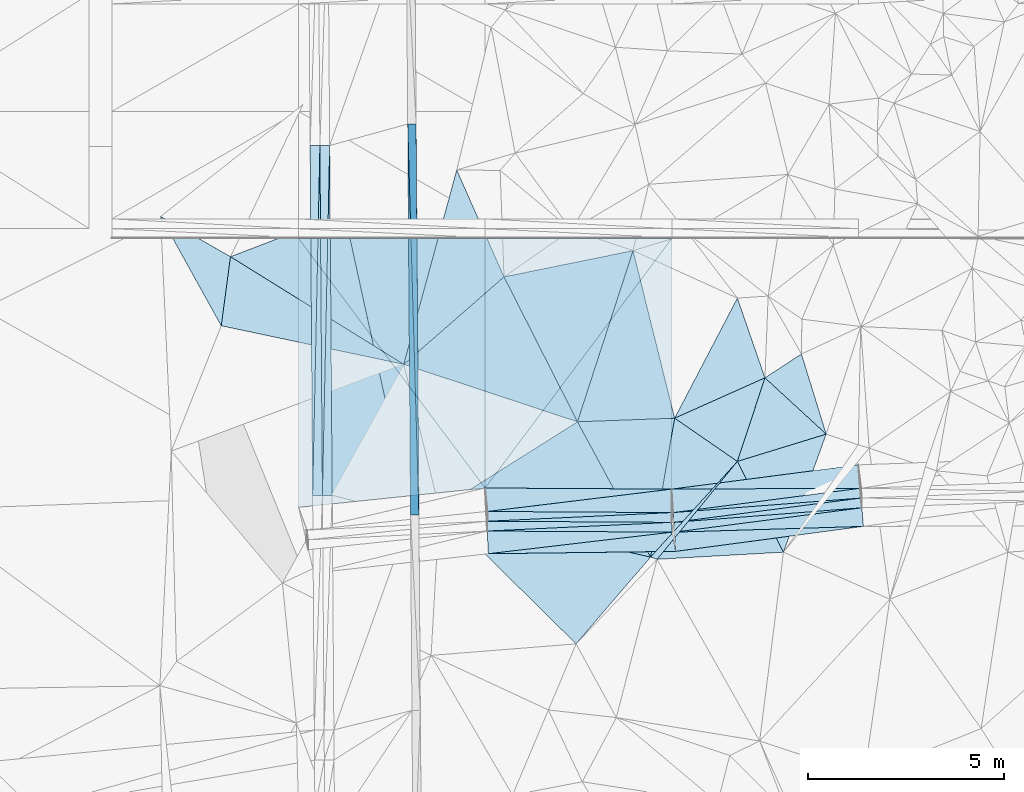
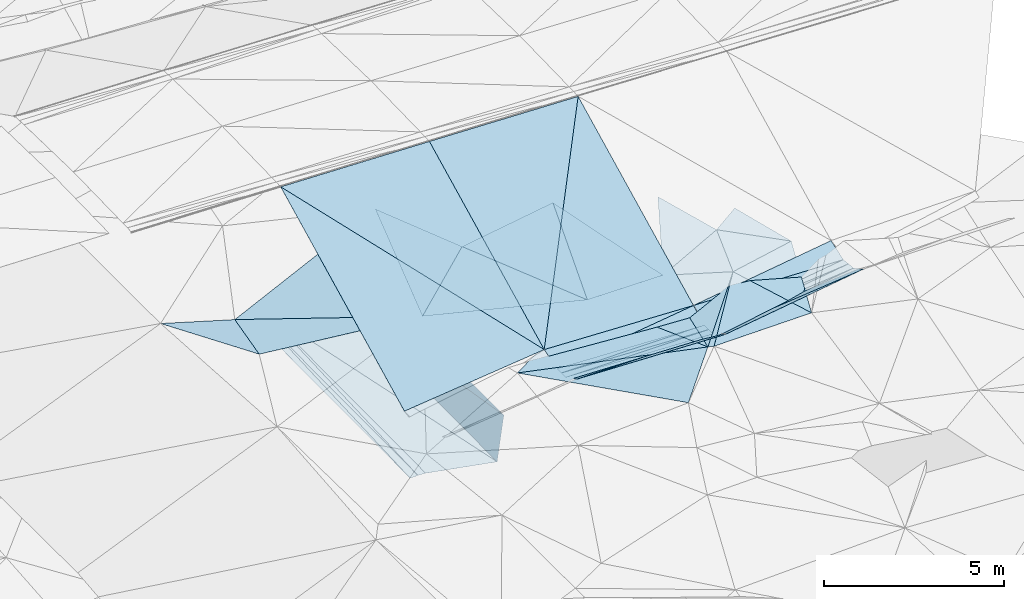
# One storey, part 101 of 275: 46 plates.
"""IFC2X3 building model written with IfcOpenShell, lengths in millimetres."""

from ifc_helpers import new_model, si_unit, frame, origin_with_axes, place, context, subcontext, project, spatial, polyline, outline, extrude, material, type_object, element, save


model = new_model("IFC2X3")

# Units and contexts
model_context = context("Model", 3, precision=1e-05, world=origin_with_axes())
body_context = subcontext(model_context, "Body", "Model", "MODEL_VIEW")
ifc_project = project(units=[si_unit("LENGTHUNIT", "METRE", prefix="MILLI"), si_unit("AREAUNIT", "SQUARE_METRE"), si_unit("VOLUMEUNIT", "CUBIC_METRE"), si_unit("MASSUNIT", "GRAM", prefix="KILO"), si_unit("TIMEUNIT", "SECOND"), si_unit("PLANEANGLEUNIT", "RADIAN"), si_unit("SOLIDANGLEUNIT", "STERADIAN"), si_unit("THERMODYNAMICTEMPERATUREUNIT", "DEGREE_CELSIUS"), si_unit("LUMINOUSINTENSITYUNIT", "LUMEN")], contexts=[model_context])

# Site, building, storey
site_placement = place(None, origin_with_axes())
site = spatial("IfcSite", under=ifc_project, at=site_placement, CompositionType="ELEMENT")
building_placement = place(site_placement, origin_with_axes())
building = spatial("IfcBuilding", under=site, at=building_placement, Name="Undefined", CompositionType="ELEMENT")
storey_placement = place(building_placement, origin_with_axes())
storey = spatial("IfcBuildingStorey", under=building, at=storey_placement, Name="Undefined", CompositionType="ELEMENT", Elevation=0.0)

# Plates
ifc_material = material()
plate_type_1 = type_object("IfcPlateType", PredefinedType="NOTDEFINED")
plate_1_placement = place(storey_placement, frame((-45467.8478214574, 62967.5282281315, 44130.6562888396), z_axis=(0.989903753044991, 0.00951870099318194, -0.141421193739993), x_axis=(0.00717855501298025, -0.999828896928451, -0.0170483199982631)))
element("IfcPlate", 1, at=plate_1_placement, inside=storey, type_object=plate_type_1, material=ifc_material, Name="00_PR", context=body_context, shape_type="SweptSolid", body=[
    extrude(outline(polyline([(0.0, 0.0), (10001.4541015625, -1.58324837684631e-08), (25.5734233856201, 1515.01306152344), (0.0, 0.0)])), frame((-8.85201319254618e-08, 2.18876761149539e-07, -0.5000001331573), z_axis=(0.0, 0.0, 1.0), x_axis=(1.0, 0.0, 0.0)), (0.0, 0.0, 1.0), 1.0),
])
plate_2_placement = place(storey_placement, frame((-45610.3318879296, 52966.2468878104, 42460.1482888606), z_axis=(0.989903753044991, 0.00951870099318194, -0.141421193739993), x_axis=(-0.007178607030507, 0.999828896503474, 0.0170483230186112)))
element("IfcPlate", 2, at=plate_2_placement, inside=storey, type_object=plate_type_1, material=ifc_material, Name="00_PR", context=body_context, shape_type="SweptSolid", body=[
    extrude(outline(polyline([(0.0, 0.0), (10001.453125, 1.13795977085829e-08), (25.5720996856689, 1515.01293945313), (0.0, 0.0)])), frame((-8.85201319254618e-08, 2.18876761149539e-07, -0.5000001331573), z_axis=(0.0, 0.0, 1.0), x_axis=(1.0, 0.0, 0.0)), (0.0, 0.0, 1.0), 1.0),
])
plate_type_2 = type_object("IfcPlateType", PredefinedType="NOTDEFINED")
plate_3_placement = place(storey_placement, frame((-47678.7505855479, 62415.9363203761, 42619.6136950579), z_axis=(-0.0500506555937917, 0.0165540146157276, -0.998609481466471), x_axis=(0.00717861900447163, -0.999830838280169, -0.0169340560163154)))
element("IfcPlate", 3, at=plate_3_placement, inside=storey, type_object=plate_type_2, material=ifc_material, Name="00_PR", context=body_context, shape_type="SweptSolid", body=[
    extrude(outline(polyline([(0.0, 0.0), (8947.4130859375, -3.28873284161091e-09), (8947.2021484375, 250.312271118164), (0.0, 0.0)])), frame((-8.85201319254618e-08, 2.18876761149539e-07, -0.5000001331573), z_axis=(0.0, 0.0, 1.0), x_axis=(1.0, 0.0, 0.0)), (0.0, 0.0, 1.0), 1.0),
])
plate_4_placement = place(storey_placement, frame((-47928.7096382133, 62414.141844496, 42632.113171124), z_axis=(0.0198711395617506, 0.0170737779132964, -0.999656753050908), x_axis=(0.00717861900447163, -0.999830838280169, -0.0169340560163154)))
element("IfcPlate", 4, at=plate_4_placement, inside=storey, type_object=plate_type_2, material=ifc_material, Name="00_PR", context=body_context, shape_type="SweptSolid", body=[
    extrude(outline(polyline([(0.0, 0.0), (8947.4140625, -1.53813743963838e-08), (8947.498046875, 250.049514770508), (0.0, 0.0)])), frame((-8.85201319254618e-08, 2.18876761149539e-07, -0.5000001331573), z_axis=(0.0, 0.0, 1.0), x_axis=(1.0, 0.0, 0.0)), (0.0, 0.0, 1.0), 1.0),
])
plate_5_placement = place(storey_placement, frame((-47864.5141266803, 53468.2408959176, 42480.5976948411), z_axis=(-0.0500506555937917, 0.0165540146157276, -0.998609481466471), x_axis=(-0.00717866302369839, 0.999830837997843, 0.0169340540250688)))
element("IfcPlate", 5, at=plate_5_placement, inside=storey, type_object=plate_type_2, material=ifc_material, Name="00_PR", context=body_context, shape_type="SweptSolid", body=[
    extrude(outline(polyline([(0.0, 0.0), (8947.4140625, -1.53813743963838e-08), (8947.2021484375, 250.31266784668), (0.0, 0.0)])), frame((-8.85201319254618e-08, 2.18876761149539e-07, -0.5000001331573), z_axis=(0.0, 0.0, 1.0), x_axis=(1.0, 0.0, 0.0)), (0.0, 0.0, 1.0), 1.0),
])
plate_6_placement = place(storey_placement, frame((-48114.4722553194, 53466.4468283167, 42475.5971724019), z_axis=(0.0198711395617506, 0.0170737779132964, -0.999656753050908), x_axis=(-0.00717866302369839, 0.999830837997843, 0.0169340540250688)))
element("IfcPlate", 6, at=plate_6_placement, inside=storey, type_object=plate_type_2, material=ifc_material, Name="00_PR", context=body_context, shape_type="SweptSolid", body=[
    extrude(outline(polyline([(0.0, 0.0), (8947.4130859375, -3.28873284161091e-09), (8947.498046875, 250.049118041992), (0.0, 0.0)])), frame((-8.85201319254618e-08, 2.18876761149539e-07, -0.5000001331573), z_axis=(0.0, 0.0, 1.0), x_axis=(1.0, 0.0, 0.0)), (0.0, 0.0, 1.0), 1.0),
])
plate_7_placement = place(storey_placement, frame((-34067.379283025, 53151.6874461131, 44876.1052519582), z_axis=(0.0316247528590593, -0.000171164612526854, -0.999499797753496), x_axis=(-0.991173271015972, -0.128815368042629, -0.0313392370606085)))
element("IfcPlate", 7, at=plate_7_placement, inside=storey, type_object=plate_type_2, material=ifc_material, Name="00_PR", context=body_context, shape_type="SweptSolid", body=[
    extrude(outline(polyline([(0.0, 0.0), (4837.89697265625, -1.20489858090878e-08), (4820.98974609375, 250.001983642578), (0.0, 0.0)])), frame((-8.85201319254618e-08, 2.18876761149539e-07, -0.5000001331573), z_axis=(0.0, 0.0, 1.0), x_axis=(1.0, 0.0, 0.0)), (0.0, 0.0, 1.0), 1.0),
])
plate_8_placement = place(storey_placement, frame((-43648.9291968445, 52557.2799648273, 44878.2282749237), z_axis=(-0.0329815252595346, -0.00248103394563388, -0.999452882062039), x_axis=(0.99834996644449, 0.0469496540668973, -0.033061676958143)))
element("IfcPlate", 8, at=plate_8_placement, inside=storey, type_object=plate_type_2, material=ifc_material, Name="00_PR", context=body_context, shape_type="SweptSolid", body=[
    extrude(outline(polyline([(0.0, 0.0), (4721.11572265625, -1.15105649456382e-08), (4728.15673828125, 250.725326538086), (0.0, 0.0)])), frame((-8.85201319254618e-08, 2.18876761149539e-07, -0.5000001331573), z_axis=(0.0, 0.0, 1.0), x_axis=(1.0, 0.0, 0.0)), (0.0, 0.0, 1.0), 1.0),
])
plate_9_placement = place(storey_placement, frame((-38878.0021077244, 52778.5896542568, 44723.958250475), z_axis=(0.0315234642456754, 0.00113587786890649, -0.999502366672245), x_axis=(0.991171161434888, 0.128815073092428, 0.0314070960772805)))
element("IfcPlate", 9, at=plate_9_placement, inside=storey, type_object=plate_type_2, material=ifc_material, Name="00_PR", context=body_context, shape_type="SweptSolid", body=[
    extrude(outline(polyline([(0.0, 0.0), (4832.63427734375, -1.35478330776095e-08), (4820.98974609375, 250.000717163086), (0.0, 0.0)])), frame((-8.85201319254618e-08, 2.18876761149539e-07, -0.5000001331573), z_axis=(0.0, 0.0, 1.0), x_axis=(1.0, 0.0, 0.0)), (0.0, 0.0, 1.0), 1.0),
])
plate_10_placement = place(storey_placement, frame((-34088.0344935457, 53401.1051120383, 44875.7372529556), z_axis=(0.0316931594194161, -0.000171001043695895, -0.999497631015031), x_axis=(-0.991171161435476, -0.128815073089597, -0.031407096070334)))
element("IfcPlate", 10, at=plate_10_placement, inside=storey, type_object=plate_type_2, material=ifc_material, Name="00_PR", context=body_context, shape_type="SweptSolid", body=[
    extrude(outline(polyline([(0.0, 0.0), (4832.63427734375, -1.35478330776095e-08), (4815.72607421875, 250.003234863281), (0.0, 0.0)])), frame((-8.85201319254618e-08, 2.18876761149539e-07, -0.5000001331573), z_axis=(0.0, 0.0, 1.0), x_axis=(1.0, 0.0, 0.0)), (0.0, 0.0, 1.0), 1.0),
])
plate_11_placement = place(storey_placement, frame((-43641.7417876802, 52807.2424494312, 44879.0702789968), z_axis=(-0.0333260849006399, 0.000200444144298951, -0.999444511660022), x_axis=(0.998339738289607, 0.0470129840465438, -0.0332798179513925)))
element("IfcPlate", 11, at=plate_11_placement, inside=storey, type_object=plate_type_2, material=ifc_material, Name="00_PR", context=body_context, shape_type="SweptSolid", body=[
    extrude(outline(polyline([(0.0, 0.0), (4715.470703125, -1.60798663273454e-09), (4702.21630859375, 249.647674560547), (0.0, 0.0)])), frame((-8.85201319254618e-08, 2.18876761149539e-07, -0.5000001331573), z_axis=(0.0, 0.0, 1.0), x_axis=(1.0, 0.0, 0.0)), (0.0, 0.0, 1.0), 1.0),
])
plate_12_placement = place(storey_placement, frame((-38893.4303008431, 53028.6894705067, 44723.4262519433), z_axis=(0.0313643726230283, 0.00407226197841773, -0.999499721266766), x_axis=(0.991164282884668, 0.128814041009528, 0.0316276330527196)))
element("IfcPlate", 12, at=plate_12_placement, inside=storey, type_object=plate_type_2, material=ifc_material, Name="00_PR", context=body_context, shape_type="SweptSolid", body=[
    extrude(outline(polyline([(0.0, 0.0), (4827.392578125, -1.26383383758366e-08), (4815.7265625, 250.00032043457), (0.0, 0.0)])), frame((-8.85201319254618e-08, 2.18876761149539e-07, -0.5000001331573), z_axis=(0.0, 0.0, 1.0), x_axis=(1.0, 0.0, 0.0)), (0.0, 0.0, 1.0), 1.0),
])
plate_13_placement = place(storey_placement, frame((-43640.2385652388, 53057.2381059913, 44879.0702793817), z_axis=(-0.0333260849006399, 0.000200444144298951, -0.999444511660022), x_axis=(0.999426433410652, -0.00601133396958282, -0.0333266869636128)))
element("IfcPlate", 13, at=plate_13_placement, inside=storey, type_object=plate_type_2, material=ifc_material, Name="00_PR", context=body_context, shape_type="SweptSolid", body=[
    extrude(outline(polyline([(0.0, 0.0), (4708.83935546875, 9.72795533016324e-09), (0.000496854190714657, 250.000183105469), (0.0, 0.0)])), frame((-8.85201319254618e-08, 2.18876761149539e-07, -0.5000001331573), z_axis=(0.0, 0.0, 1.0), x_axis=(1.0, 0.0, 0.0)), (0.0, 0.0, 1.0), 1.0),
])
plate_type_3 = type_object("IfcPlateType", PredefinedType="NOTDEFINED")
plate_14_placement = place(storey_placement, frame((-47678.72525252, 62415.9365698354, 42619.6130723479), z_axis=(0.000617325314116494, 0.0170531898071072, -0.999854393212761), x_axis=(0.964053322277793, 0.265659394080784, 0.00512622100387193)))
element("IfcPlate", 14, at=plate_14_placement, inside=storey, type_object=plate_type_3, material=ifc_material, Name="00_PR", context=body_context, shape_type="SweptSolid", body=[
    extrude(outline(polyline([(0.0, 0.0), (2070.53100585938, 6.95581547915936e-09), (-517.65283203125, 9660.7646484375), (0.0, 0.0)])), frame((-8.85201319254618e-08, 2.18876761149539e-07, -0.5000001331573), z_axis=(0.0, 0.0, 1.0), x_axis=(1.0, 0.0, 0.0)), (0.0, 0.0, 1.0), 1.0),
])
plate_type_4 = type_object("IfcPlateType", PredefinedType="NOTDEFINED")
plate_15_placement = place(storey_placement, frame((-45610.8268012711, 52966.2505958649, 42459.719071082), z_axis=(7.72798893792599e-05, 0.0169350475297483, -0.999856588813108), x_axis=(-0.969806907114547, 0.243840356001304, 0.00405508299231664)))
element("IfcPlate", 15, at=plate_15_placement, inside=storey, type_object=plate_type_4, material=ifc_material, Name="00_PR", context=body_context, shape_type="SweptSolid", body=[
    extrude(outline(polyline([(0.0, 0.0), (2066.04907226563, -2.7648638933897e-09), (4310.32568359375, 8661.3759765625), (0.0, 0.0)])), frame((-8.85201319254618e-08, 2.18876761149539e-07, -0.5000001331573), z_axis=(0.0, 0.0, 1.0), x_axis=(1.0, 0.0, 0.0)), (0.0, 0.0, 1.0), 1.0),
])
plate_type_5 = type_object("IfcPlateType", PredefinedType="NOTDEFINED")
plate_16_placement = place(storey_placement, frame((-38856.166571228, 55443.242871549, 44919.5008934247), z_axis=(-0.0378885010470703, 0.0464931763728615, -0.99819980266436), x_axis=(-0.998652384357972, -0.0372153176308535, 0.0361723008636617)))
element("IfcPlate", 16, at=plate_16_placement, inside=storey, type_object=plate_type_5, material=ifc_material, Name="00", context=body_context, shape_type="SweptSolid", body=[
    extrude(outline(polyline([(0.0, 0.0), (2488.09155273438, 5.98811311647296e-09), (911.5419921875, 4327.4462890625), (0.0, 0.0)])), frame((-8.85201319254618e-08, 2.18876761149539e-07, -0.5000001331573), z_axis=(0.0, 0.0, 1.0), x_axis=(1.0, 0.0, 0.0)), (0.0, 0.0, 1.0), 1.0),
])
plate_type_6 = type_object("IfcPlateType", PredefinedType="NOTDEFINED")
plate_17_placement = place(storey_placement, frame((-43641.7417750498, 52807.2445107073, 44879.0702832059), z_axis=(-0.0333009973697792, 0.0043241866607462, -0.999436013451537), x_axis=(0.999426433410652, -0.00601133396958282, -0.0333266869636128)))
element("IfcPlate", 17, at=plate_17_placement, inside=storey, type_object=plate_type_6, material=ifc_material, Name="00_PR", context=body_context, shape_type="SweptSolid", body=[
    extrude(outline(polyline([(0.0, 0.0), (4708.8388671875, 3.24507709592581e-09), (-5.65279674530029, 250.001983642578), (0.0, 0.0)])), frame((-8.85201319254618e-08, 2.18876761149539e-07, -0.5000001331573), z_axis=(0.0, 0.0, 1.0), x_axis=(1.0, 0.0, 0.0)), (0.0, 0.0, 1.0), 1.0),
])
plate_type_7 = type_object("IfcPlateType", PredefinedType="NOTDEFINED")
plate_18_placement = place(storey_placement, frame((-34027.9627766555, 52675.8517057261, 45114.5213422296), z_axis=(0.0855274373855107, -0.44120931679986, -0.893319313696546), x_axis=(-0.99083210094334, -0.131776084032149, -0.0297793790626996)))
element("IfcPlate", 18, at=plate_18_placement, inside=storey, type_object=plate_type_7, material=ifc_material, Name="00_PR", context=body_context, shape_type="SweptSolid", body=[
    extrude(outline(polyline([(0.0, 0.0), (4848.72412109375, 5.03860064782202e-09), (4821.32177734375, 549.473449707031), (0.0, 0.0)])), frame((-8.85201319254618e-08, 2.18876761149539e-07, -0.5000001331573), z_axis=(0.0, 0.0, 1.0), x_axis=(1.0, 0.0, 0.0)), (0.0, 0.0, 1.0), 1.0),
])
plate_type_8 = type_object("IfcPlateType", PredefinedType="NOTDEFINED")
plate_19_placement = place(storey_placement, frame((-38862.5464775777, 52528.2716883468, 44724.5422254064), z_axis=(0.0855317991661072, -0.440736080650697, -0.893552471063715), x_axis=(0.991173271016298, 0.128815368039797, 0.0313392370619334)))
element("IfcPlate", 19, at=plate_19_placement, inside=storey, type_object=plate_type_8, material=ifc_material, Name="00_PR", context=body_context, shape_type="SweptSolid", body=[
    extrude(outline(polyline([(0.0, 0.0), (4837.89697265625, -1.20489858090878e-08), (4823.142578125, 533.254699707031), (0.0, 0.0)])), frame((-8.85201319254618e-08, 2.18876761149539e-07, -0.5000001331573), z_axis=(0.0, 0.0, 1.0), x_axis=(1.0, 0.0, 0.0)), (0.0, 0.0, 1.0), 1.0),
])
plate_type_9 = type_object("IfcPlateType", PredefinedType="NOTDEFINED")
plate_20_placement = place(storey_placement, frame((-38832.2928365396, 52036.899257595, 44970.1308471199), z_axis=(-0.0311474346468299, -0.454291144797357, -0.890308594293927), x_axis=(-0.999063808976224, -0.0126046490458891, 0.041383914947093)))
element("IfcPlate", 20, at=plate_20_placement, inside=storey, type_object=plate_type_9, material=ifc_material, Name="00_PR", context=body_context, shape_type="SweptSolid", body=[
    extrude(outline(polyline([(0.0, 0.0), (4792.77978515625, -1.70512066688389e-08), (67.9575119018555, 552.95068359375), (0.0, 0.0)])), frame((-8.85201319254618e-08, 2.18876761149539e-07, -0.5000001331573), z_axis=(0.0, 0.0, 1.0), x_axis=(1.0, 0.0, 0.0)), (0.0, 0.0, 1.0), 1.0),
])
plate_type_10 = type_object("IfcPlateType", PredefinedType="NOTDEFINED")
plate_21_placement = place(storey_placement, frame((-43648.9287882688, 52557.05714222, 44878.2813053718), z_axis=(-0.0321635862019478, -0.448125900417467, -0.893391672838775), x_axis=(0.999438391171871, -0.00601139395231152, -0.0329661249547641)))
element("IfcPlate", 21, at=plate_21_placement, inside=storey, type_object=plate_type_10, material=ifc_material, Name="00_PR", context=body_context, shape_type="SweptSolid", body=[
    extrude(outline(polyline([(0.0, 0.0), (4734.7998046875, -5.38057065568864e-09), (22.2500171661377, 649.289306640625), (0.0, 0.0)])), frame((-8.85201319254618e-08, 2.18876761149539e-07, -0.5000001331573), z_axis=(0.0, 0.0, 1.0), x_axis=(1.0, 0.0, 0.0)), (0.0, 0.0, 1.0), 1.0),
])
plate_type_11 = type_object("IfcPlateType", PredefinedType="NOTDEFINED")
plate_22_placement = place(storey_placement, frame((-43640.2354667973, 53057.4615968659, 44879.1229848145), z_axis=(-0.0271223425560844, 0.44718545969689, -0.894029945342969), x_axis=(0.992262441414329, 0.120443698055343, 0.0301423780951294)))
element("IfcPlate", 22, at=plate_22_placement, inside=storey, type_object=plate_type_11, material=ifc_material, Name="00_PR", context=body_context, shape_type="SweptSolid", body=[
    extrude(outline(polyline([(0.0, 0.0), (4746.4736328125, 1.65891833603382e-08), (4661.58447265625, 665.428466796875), (0.0, 0.0)])), frame((-8.85201319254618e-08, 2.18876761149539e-07, -0.5000001331573), z_axis=(0.0, 0.0, 1.0), x_axis=(1.0, 0.0, 0.0)), (0.0, 0.0, 1.0), 1.0),
])
plate_type_12 = type_object("IfcPlateType", PredefinedType="NOTDEFINED")
plate_23_placement = place(storey_placement, frame((-34108.7214605178, 53650.7453296254, 44876.1572030551), z_axis=(-0.0291134470068944, 0.443910154674139, -0.895598225646165), x_axis=(-0.991164282885133, -0.12881404100623, -0.0316276330515694)))
element("IfcPlate", 23, at=plate_23_placement, inside=storey, type_object=plate_type_12, material=ifc_material, Name="00_PR", context=body_context, shape_type="SweptSolid", body=[
    extrude(outline(polyline([(0.0, 0.0), (4827.392578125, -1.26383383758366e-08), (4777.32763671875, 669.607971191406), (0.0, 0.0)])), frame((-8.85201319254618e-08, 2.18876761149539e-07, -0.5000001331573), z_axis=(0.0, 0.0, 1.0), x_axis=(1.0, 0.0, 0.0)), (0.0, 0.0, 1.0), 1.0),
])
plate_24_placement = place(storey_placement, frame((-43702.6438388523, 53657.8464859003, 45179.1223353477), z_axis=(-0.0267684028118271, 0.444595291207925, -0.895331491486055), x_axis=(0.999441683842272, -0.00601139898007021, -0.0328661479462663)))
element("IfcPlate", 24, at=plate_24_placement, inside=storey, type_object=plate_type_12, material=ifc_material, Name="00_PR", context=body_context, shape_type="SweptSolid", body=[
    extrude(outline(polyline([(0.0, 0.0), (4774.82177734375, 2.47382558882236e-09), (75.8427124023438, 669.78076171875), (0.0, 0.0)])), frame((-8.85201319254618e-08, 2.18876761149539e-07, -0.5000001331573), z_axis=(0.0, 0.0, 1.0), x_axis=(1.0, 0.0, 0.0)), (0.0, 0.0, 1.0), 1.0),
])
plate_type_13 = type_object("IfcPlateType", PredefinedType="NOTDEFINED")
plate_25_placement = place(storey_placement, frame((-38930.4890261028, 53629.1443287068, 45022.1929686254), z_axis=(-0.0290807825301417, 0.446995654367649, -0.89406330484137), x_axis=(0.991147357858067, 0.128811913981622, 0.0321621800779211)))
element("IfcPlate", 25, at=plate_25_placement, inside=storey, type_object=plate_type_13, material=ifc_material, Name="00_PR", context=body_context, shape_type="SweptSolid", body=[
    extrude(outline(polyline([(0.0, 0.0), (4814.81689453125, 1.49302650243044e-08), (4777.16796875, 670.746459960938), (0.0, 0.0)])), frame((-8.85201319254618e-08, 2.18876761149539e-07, -0.5000001331573), z_axis=(0.0, 0.0, 1.0), x_axis=(1.0, 0.0, 0.0)), (0.0, 0.0, 1.0), 1.0),
])
plate_type_14 = type_object("IfcPlateType", PredefinedType="NOTDEFINED")
plate_26_placement = place(storey_placement, frame((-38930.1210553255, 60039.3448970351, 48227.2939467437), z_axis=(-0.0267133510371116, 0.447055305363993, -0.894107348600981), x_axis=(-5.11789581372139e-05, -0.894427148801689, -0.447213676967951)))
element("IfcPlate", 26, at=plate_26_placement, inside=storey, type_object=plate_type_14, material=ifc_material, Name="00_PR", context=body_context, shape_type="SweptSolid", body=[
    extrude(outline(polyline([(0.0, 0.0), (7166.822265625, 7.89441401138902e-09), (7071.21240234375, 4773.8642578125), (0.0, 0.0)])), frame((-8.85201319254618e-08, 2.18876761149539e-07, -0.5000001331573), z_axis=(0.0, 0.0, 1.0), x_axis=(1.0, 0.0, 0.0)), (0.0, 0.0, 1.0), 1.0),
])
plate_type_15 = type_object("IfcPlateType", PredefinedType="NOTDEFINED")
plate_27_placement = place(storey_placement, frame((-43702.276422834, 60039.6183177682, 48370.0079192829), z_axis=(-0.0243413645537518, 0.447082173079789, -0.894161634429657), x_axis=(-5.11789581372139e-05, -0.894427148801689, -0.447213676967951)))
element("IfcPlate", 27, at=plate_27_placement, inside=storey, type_object=plate_type_15, material=ifc_material, Name="00_PR", context=body_context, shape_type="SweptSolid", body=[
    extrude(outline(polyline([(0.0, 0.0), (7135.0361328125, 1.42172211781144e-08), (-58.1583938598633, 4773.57373046875), (0.0, 0.0)])), frame((-8.85201319254618e-08, 2.18876761149539e-07, -0.5000001331573), z_axis=(0.0, 0.0, 1.0), x_axis=(1.0, 0.0, 0.0)), (0.0, 0.0, 1.0), 1.0),
])
plate_type_16 = type_object("IfcPlateType", PredefinedType="NOTDEFINED")
plate_28_placement = place(storey_placement, frame((-38930.1210553255, 60039.3448970351, 48227.2939467437), z_axis=(-0.0267133510371116, 0.447055305363993, -0.894107348600981), x_axis=(-0.559379697953522, -0.747964996961866, -0.35727120907969)))
element("IfcPlate", 28, at=plate_28_placement, inside=storey, type_object=plate_type_16, material=ifc_material, Name="00_PR", context=body_context, shape_type="SweptSolid", body=[
    extrude(outline(polyline([(0.0, 0.0), (8531.8125, 2.82307155430317e-08), (2618.25537109375, 3992.31567382813), (0.0, 0.0)])), frame((-8.85201319254618e-08, 2.18876761149539e-07, -0.5000001331573), z_axis=(0.0, 0.0, 1.0), x_axis=(1.0, 0.0, 0.0)), (0.0, 0.0, 1.0), 1.0),
])
plate_type_17 = type_object("IfcPlateType", PredefinedType="NOTDEFINED")
plate_29_placement = place(storey_placement, frame((-43702.6426279347, 53657.8477288794, 45179.1229188863), z_axis=(-0.0243413645537518, 0.447082173079789, -0.894161634429657), x_axis=(-0.994339666083705, -0.103358287016893, -0.0246108300851499)))
element("IfcPlate", 29, at=plate_29_placement, inside=storey, type_object=plate_type_17, material=ifc_material, Name="00_PR", context=body_context, shape_type="SweptSolid", body=[
    extrude(outline(polyline([(0.0, 0.0), (4799.3505859375, 1.07538653537631e-08), (4003.41235351563, 7648.6435546875), (0.0, 0.0)])), frame((-8.85201319254618e-08, 2.18876761149539e-07, -0.5000001331573), z_axis=(0.0, 0.0, 1.0), x_axis=(1.0, 0.0, 0.0)), (0.0, 0.0, 1.0), 1.0),
])
plate_type_18 = type_object("IfcPlateType", PredefinedType="NOTDEFINED")
plate_30_placement = place(storey_placement, frame((-38856.0790477631, 55443.2160961774, 44919.5047310186), z_axis=(0.137155950317017, -0.00706030059971147, -0.990524304319726), x_axis=(0.817646804480152, -0.563657268629875, 0.117235603142155)))
element("IfcPlate", 30, at=plate_30_placement, inside=storey, type_object=plate_type_18, material=ifc_material, Name="00", context=body_context, shape_type="SweptSolid", body=[
    extrude(outline(polyline([(0.0, 0.0), (1961.861328125, 1.1423253454268e-09), (1491.54272460938, 3283.12353515625), (0.0, 0.0)])), frame((-8.85201319254618e-08, 2.18876761149539e-07, -0.5000001331573), z_axis=(0.0, 0.0, 1.0), x_axis=(1.0, 0.0, 0.0)), (0.0, 0.0, 1.0), 1.0),
])
plate_type_19 = type_object("IfcPlateType", PredefinedType="NOTDEFINED")
plate_31_placement = place(storey_placement, frame((-37252.0225705228, 54337.4472443682, 45149.5022630688), z_axis=(0.0307664629451319, 0.0900697500554237, -0.995460127218966), x_axis=(-0.631494828801318, -0.770231227712464, -0.089208391162179)))
element("IfcPlate", 31, at=plate_31_placement, inside=storey, type_object=plate_type_19, material=ifc_material, Name="00", context=body_context, shape_type="SweptSolid", body=[
    extrude(outline(polyline([(0.0, 0.0), (3250.81518554688, 2.51020537689328e-09), (3312.4921875, 165.819076538086), (0.0, 0.0)])), frame((-8.85201319254618e-08, 2.18876761149539e-07, -0.5000001331573), z_axis=(0.0, 0.0, 1.0), x_axis=(1.0, 0.0, 0.0)), (0.0, 0.0, 1.0), 1.0),
])
plate_type_20 = type_object("IfcPlateType", PredefinedType="NOTDEFINED")
plate_32_placement = place(storey_placement, frame((-37250.9361247661, 58514.5768867608, 45159.5012642316), z_axis=(0.0165334503181676, 0.0693025650427253, -0.997458670571907), x_axis=(0.326037811644831, -0.943441516982, -0.0601452359921651)))
element("IfcPlate", 32, at=plate_32_placement, inside=storey, type_object=plate_type_20, material=ifc_material, Name="00", context=body_context, shape_type="SweptSolid", body=[
    extrude(outline(polyline([(0.0, 0.0), (2161.43481445313, -5.03496266901493e-09), (2388.69116210938, 2522.1923828125), (0.0, 0.0)])), frame((-8.85201319254618e-08, 2.18876761149539e-07, -0.5000001331573), z_axis=(0.0, 0.0, 1.0), x_axis=(1.0, 0.0, 0.0)), (0.0, 0.0, 1.0), 1.0),
])
plate_type_21 = type_object("IfcPlateType", PredefinedType="NOTDEFINED")
plate_33_placement = place(storey_placement, frame((-50451.82340233, 57806.363677281, 44869.5013586294), z_axis=(0.0738939266930767, 0.00141975776049022, -0.9972650960932), x_axis=(-0.485071623709287, 0.873785761065617, -0.0346981790734939)))
element("IfcPlate", 33, at=plate_33_placement, inside=storey, type_object=plate_type_21, material=ifc_material, Name="00", context=body_context, shape_type="SweptSolid", body=[
    extrude(outline(polyline([(0.0, 0.0), (3199.01513671875, 1.24055077321827e-09), (1428.15515136719, 1065.8671875), (0.0, 0.0)])), frame((-8.85201319254618e-08, 2.18876761149539e-07, -0.5000001331573), z_axis=(0.0, 0.0, 1.0), x_axis=(1.0, 0.0, 0.0)), (0.0, 0.0, 1.0), 1.0),
])
plate_type_22 = type_object("IfcPlateType", PredefinedType="NOTDEFINED")
plate_34_placement = place(storey_placement, frame((-44429.1022578891, 61791.9761452207, 45269.5002574984), z_axis=(0.0217327051902829, 0.0242271434442089, -0.99947022719321), x_axis=(0.404307418432706, -0.914525327435976, -0.0133767289873725)))
element("IfcPlate", 34, at=plate_34_placement, inside=storey, type_object=plate_type_22, material=ifc_material, Name="00", context=body_context, shape_type="SweptSolid", body=[
    extrude(outline(polyline([(0.0, 0.0), (2990.267578125, 7.95989762991667e-09), (4001.64868164063, 3251.431640625), (0.0, 0.0)])), frame((-8.85201319254618e-08, 2.18876761149539e-07, -0.5000001331573), z_axis=(0.0, 0.0, 1.0), x_axis=(1.0, 0.0, 0.0)), (0.0, 0.0, 1.0), 1.0),
])
plate_type_23 = type_object("IfcPlateType", PredefinedType="NOTDEFINED")
plate_35_placement = place(storey_placement, frame((-41340.9013408941, 55350.646500462, 45009.5007043145), z_axis=(-0.0301351775826074, 0.0439899059104854, -0.998577367683672), x_axis=(-0.451561559645267, 0.890672547912452, 0.0528636949699351)))
element("IfcPlate", 35, at=plate_35_placement, inside=storey, type_object=plate_type_23, material=ifc_material, Name="00", context=body_context, shape_type="SweptSolid", body=[
    extrude(outline(polyline([(0.0, 0.0), (4161.646484375, 1.50539563037455e-08), (3266.03930664063, 3247.35083007813), (0.0, 0.0)])), frame((-8.85201319254618e-08, 2.18876761149539e-07, -0.5000001331573), z_axis=(0.0, 0.0, 1.0), x_axis=(1.0, 0.0, 0.0)), (0.0, 0.0, 1.0), 1.0),
])
plate_type_24 = type_object("IfcPlateType", PredefinedType="NOTDEFINED")
plate_36_placement = place(storey_placement, frame((-34980.3442819455, 55035.5888677754, 44969.5006798855), z_axis=(0.00913768592621785, 0.0515534780230549, -0.998628430197959), x_axis=(-0.735831181120335, 0.676577804282511, 0.0281948158942242)))
element("IfcPlate", 36, at=plate_36_placement, inside=storey, type_object=plate_type_24, material=ifc_material, Name="00", context=body_context, shape_type="SweptSolid", body=[
    extrude(outline(polyline([(0.0, 0.0), (2128.05078125, 7.23593984730542e-09), (1854.7490234375, 1081.34460449219), (0.0, 0.0)])), frame((-8.85201319254618e-08, 2.18876761149539e-07, -0.5000001331573), z_axis=(0.0, 0.0, 1.0), x_axis=(1.0, 0.0, 0.0)), (0.0, 0.0, 1.0), 1.0),
])
plate_type_25 = type_object("IfcPlateType", PredefinedType="NOTDEFINED")
plate_37_placement = place(storey_placement, frame((-50215.850788533, 59572.6074174416, 44889.5007341995), z_axis=(0.0543362979805808, 0.00404694186210964, -0.998514491123354), x_axis=(0.848601402161896, -0.527196343401382, 0.0440417501136822)))
element("IfcPlate", 37, at=plate_37_placement, inside=storey, type_object=plate_type_25, material=ifc_material, Name="00", context=body_context, shape_type="SweptSolid", body=[
    extrude(outline(polyline([(0.0, 0.0), (5222.3173828125, 2.40106601268053e-09), (730.020751953125, 1625.65979003906), (0.0, 0.0)])), frame((-8.85201319254618e-08, 2.18876761149539e-07, -0.5000001331573), z_axis=(0.0, 0.0, 1.0), x_axis=(1.0, 0.0, 0.0)), (0.0, 0.0, 1.0), 1.0),
])
plate_type_26 = type_object("IfcPlateType", PredefinedType="NOTDEFINED")
plate_38_placement = place(storey_placement, frame((-41340.8893533093, 55350.6525733172, 45009.5007906748), z_axis=(-0.00616084384314548, 0.0561343617345375, -0.998404215453739), x_axis=(-0.94920757751663, 0.313771861542794, 0.0234988018626408)))
element("IfcPlate", 38, at=plate_38_placement, inside=storey, type_object=plate_type_26, material=ifc_material, Name="00", context=body_context, shape_type="SweptSolid", body=[
    extrude(outline(polyline([(0.0, 0.0), (4681.08984375, -2.40106601268053e-10), (2952.00512695313, 2933.42236328125), (0.0, 0.0)])), frame((-8.85201319254618e-08, 2.18876761149539e-07, -0.5000001331573), z_axis=(0.0, 0.0, 1.0), x_axis=(1.0, 0.0, 0.0)), (0.0, 0.0, 1.0), 1.0),
])
plate_type_27 = type_object("IfcPlateType", PredefinedType="NOTDEFINED")
plate_39_placement = place(storey_placement, frame((-37252.0589683434, 54337.4766519598, 45149.5060128364), z_axis=(-0.0420295970287439, 0.148885001268348, -0.987960914900446), x_axis=(0.447683618660427, -0.88120559094805, -0.151842299985886)))
element("IfcPlate", 39, at=plate_39_placement, inside=storey, type_object=plate_type_27, material=ifc_material, Name="00", context=body_context, shape_type="SweptSolid", body=[
    extrude(outline(polyline([(0.0, 0.0), (2634.31201171875, -1.41244527185336e-09), (1331.42919921875, 2965.65283203125), (0.0, 0.0)])), frame((-8.85201319254618e-08, 2.18876761149539e-07, -0.5000001331573), z_axis=(0.0, 0.0, 1.0), x_axis=(1.0, 0.0, 0.0)), (0.0, 0.0, 1.0), 1.0),
])
plate_type_28 = type_object("IfcPlateType", PredefinedType="NOTDEFINED")
plate_40_placement = place(storey_placement, frame((-36546.2693401132, 56475.3383676496, 45029.5014547118), z_axis=(-0.0687837429348832, -0.0332568063383611, -0.9970771191538), x_axis=(0.735831181112236, -0.676577804291819, -0.0281948158822333)))
element("IfcPlate", 40, at=plate_40_placement, inside=storey, type_object=plate_type_28, material=ifc_material, Name="00", context=body_context, shape_type="SweptSolid", body=[
    extrude(outline(polyline([(0.0, 0.0), (2128.05078125, 7.23593984730542e-09), (923.756164550781, 2056.71459960938), (0.0, 0.0)])), frame((-8.85201319254618e-08, 2.18876761149539e-07, -0.5000001331573), z_axis=(0.0, 0.0, 1.0), x_axis=(1.0, 0.0, 0.0)), (0.0, 0.0, 1.0), 1.0),
])
plate_type_29 = type_object("IfcPlateType", PredefinedType="NOTDEFINED")
plate_41_placement = place(storey_placement, frame((-39472.3496845195, 51890.7226057554, 44859.500472006), z_axis=(-0.0370547003421271, 0.0233004330096618, -0.999041560198632), x_axis=(-0.474843292471277, 0.879244464610903, 0.0381184869338198)))
element("IfcPlate", 41, at=plate_41_placement, inside=storey, type_object=plate_type_29, material=ifc_material, Name="00", context=body_context, shape_type="SweptSolid", body=[
    extrude(outline(polyline([(0.0, 0.0), (3935.09838867188, -6.85759005136788e-10), (2833.21997070313, 2230.79907226563), (0.0, 0.0)])), frame((-8.85201319254618e-08, 2.18876761149539e-07, -0.5000001331573), z_axis=(0.0, 0.0, 1.0), x_axis=(1.0, 0.0, 0.0)), (0.0, 0.0, 1.0), 1.0),
])
plate_type_30 = type_object("IfcPlateType", PredefinedType="NOTDEFINED")
plate_42_placement = place(storey_placement, frame((-41377.4463855957, 49670.8335250197, 44979.5006592572), z_axis=(-0.0505168372158979, -0.0106316370178327, -0.998666619774599), x_axis=(-0.711101478807195, 0.702511855961047, 0.0284917369141742)))
element("IfcPlate", 42, at=plate_42_placement, inside=storey, type_object=plate_type_30, material=ifc_material, Name="00", context=body_context, shape_type="SweptSolid", body=[
    extrude(outline(polyline([(0.0, 0.0), (4913.70556640625, -6.69660948915407e-09), (201.355178833008, 2920.79711914063), (0.0, 0.0)])), frame((-8.85201319254618e-08, 2.18876761149539e-07, -0.5000001331573), z_axis=(0.0, 0.0, 1.0), x_axis=(1.0, 0.0, 0.0)), (0.0, 0.0, 1.0), 1.0),
])
plate_type_31 = type_object("IfcPlateType", PredefinedType="NOTDEFINED")
plate_43_placement = place(storey_placement, frame((-37251.9956152682, 54337.3603702232, 45149.5035479654), z_axis=(0.0846740590269606, -0.0836827740361142, -0.992888461539119), x_axis=(-0.817646804483758, 0.563657268626956, -0.117235603131037)))
element("IfcPlate", 43, at=plate_43_placement, inside=storey, type_object=plate_type_31, material=ifc_material, Name="00", context=body_context, shape_type="SweptSolid", body=[
    extrude(outline(polyline([(0.0, 0.0), (1961.861328125, 1.1423253454268e-09), (642.043334960938, 2161.29125976563), (0.0, 0.0)])), frame((-8.85201319254618e-08, 2.18876761149539e-07, -0.5000001331573), z_axis=(0.0, 0.0, 1.0), x_axis=(1.0, 0.0, 0.0)), (0.0, 0.0, 1.0), 1.0),
])
plate_type_32 = type_object("IfcPlateType", PredefinedType="NOTDEFINED")
plate_44_placement = place(storey_placement, frame((-36072.7560724131, 52016.0880805902, 44749.5063997809), z_axis=(-0.112875789927944, 0.112759806943525, -0.987190094149147), x_axis=(-0.447683618726401, 0.881205590915948, 0.151842299977672)))
element("IfcPlate", 44, at=plate_44_placement, inside=storey, type_object=plate_type_32, material=ifc_material, Name="00", context=body_context, shape_type="SweptSolid", body=[
    extrude(outline(polyline([(0.0, 0.0), (2634.31201171875, -1.41244527185336e-09), (2205.20581054688, 2344.412109375), (0.0, 0.0)])), frame((-8.85201319254618e-08, 2.18876761149539e-07, -0.5000001331573), z_axis=(0.0, 0.0, 1.0), x_axis=(1.0, 0.0, 0.0)), (0.0, 0.0, 1.0), 1.0),
])
plate_type_33 = type_object("IfcPlateType", PredefinedType="NOTDEFINED")
plate_45_placement = place(storey_placement, frame((-45784.1818936269, 56819.4255489127, 45119.5009496274), z_axis=(0.0602963140488178, 0.0136762063191592, -0.99808682783255), x_axis=(-0.848601402196514, 0.527196343343678, -0.0440417501374024)))
element("IfcPlate", 45, at=plate_45_placement, inside=storey, type_object=plate_type_33, material=ifc_material, Name="00", context=body_context, shape_type="SweptSolid", body=[
    extrude(outline(polyline([(0.0, 0.0), (5222.3173828125, 2.40106601268053e-09), (1464.96264648438, 4943.56982421875), (0.0, 0.0)])), frame((-8.85201319254618e-08, 2.18876761149539e-07, -0.5000001331573), z_axis=(0.0, 0.0, 1.0), x_axis=(1.0, 0.0, 0.0)), (0.0, 0.0, 1.0), 1.0),
])
plate_type_34 = type_object("IfcPlateType", PredefinedType="NOTDEFINED")
plate_46_placement = place(storey_placement, frame((-41340.9081124322, 55350.6343864169, 45009.5005678945), z_axis=(-0.0435900763316727, 0.0197628178357806, -0.998854011493466), x_axis=(0.474843292386587, -0.879244464658248, -0.0381184868967437)))
element("IfcPlate", 46, at=plate_46_placement, inside=storey, type_object=plate_type_34, material=ifc_material, Name="00", context=body_context, shape_type="SweptSolid", body=[
    extrude(outline(polyline([(0.0, 0.0), (3935.09838867188, -6.85759005136788e-10), (278.112487792969, 4166.98388671875), (0.0, 0.0)])), frame((-8.85201319254618e-08, 2.18876761149539e-07, -0.5000001331573), z_axis=(0.0, 0.0, 1.0), x_axis=(1.0, 0.0, 0.0)), (0.0, 0.0, 1.0), 1.0),
])

save(model, "model.ifc")
